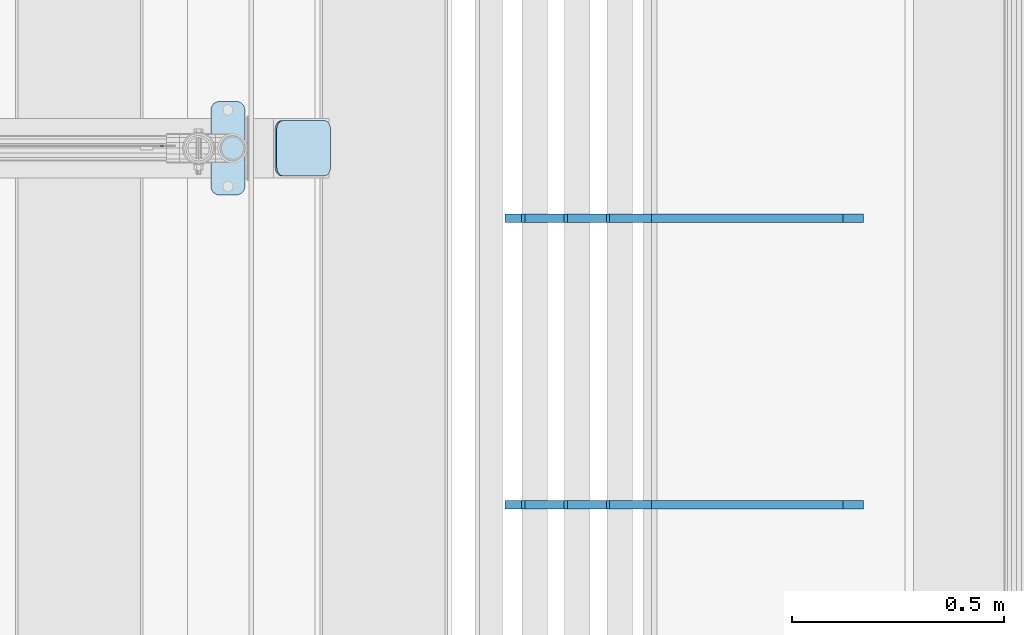
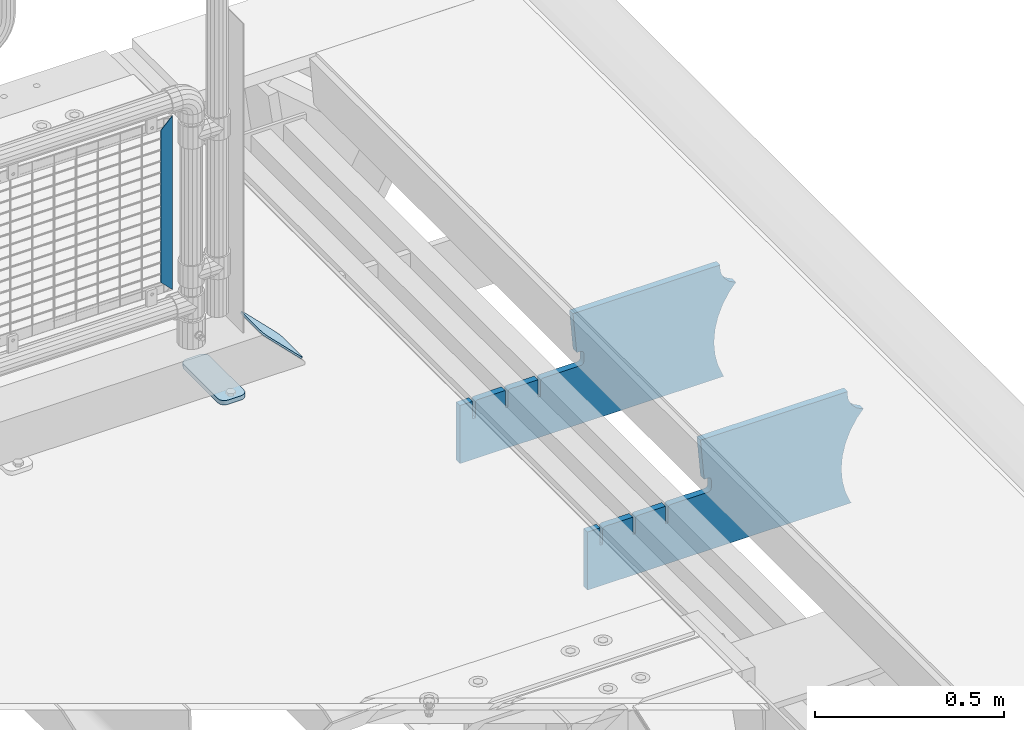
# One storey, part 178 of 193: 5 plates.
"""IFC2X3 building model written with IfcOpenShell, lengths in millimetres."""

from ifc_helpers import new_model, si_unit, frame, origin_with_axes, place, context, subcontext, project, spatial, faceted_brep, material, type_object, element, save


model = new_model("IFC2X3")

# Units and contexts
model_context = context("Model", 3, precision=1e-05, world=origin_with_axes())
body_context = subcontext(model_context, "Body", "Model", "MODEL_VIEW")
ifc_project = project(units=[si_unit("LENGTHUNIT", "METRE", prefix="MILLI"), si_unit("AREAUNIT", "SQUARE_METRE"), si_unit("VOLUMEUNIT", "CUBIC_METRE"), si_unit("MASSUNIT", "GRAM", prefix="KILO"), si_unit("TIMEUNIT", "SECOND"), si_unit("PLANEANGLEUNIT", "RADIAN"), si_unit("SOLIDANGLEUNIT", "STERADIAN"), si_unit("THERMODYNAMICTEMPERATUREUNIT", "DEGREE_CELSIUS"), si_unit("LUMINOUSINTENSITYUNIT", "LUMEN")], contexts=[model_context])

# Site, building, storey
site_placement = place(None, origin_with_axes())
site = spatial("IfcSite", under=ifc_project, at=site_placement, CompositionType="ELEMENT")
building_placement = place(site_placement, origin_with_axes())
building = spatial("IfcBuilding", under=site, at=building_placement, Name="Standard", CompositionType="ELEMENT")
storey_placement = place(building_placement, origin_with_axes())
storey = spatial("IfcBuildingStorey", under=building, at=storey_placement, Name="Undefined", CompositionType="ELEMENT", Elevation=0.0)

# Plates
ifc_material_1 = material(Name="Misc_Undefined")
plate_type_1 = type_object("IfcPlateType", PredefinedType="NOTDEFINED")
plate_1_placement = place(storey_placement, frame((-29073.5000000138, 28670.4997788013, 914.461469028508), z_axis=(0.706514791587334, 1.30000007553929e-08, -0.707698275586641), x_axis=(-0.707698275586628, 0.0, -0.706514791587347)))
element("IfcPlate", 1, at=plate_1_placement, inside=storey, type_object=plate_type_1, material=ifc_material_1, context=body_context, shape_type="Brep", body=[
    faceted_brep([(0.0, -1.49999999999636, 3.63797880709171e-12), (397.726470947258, -1.50000000000364, 398.392700195313), (397.726470947258, 1.49999999999636, 398.392700195316), (0.0, 1.50000000000364, 7.27595761418343e-12), (397.767883300774, -1.5, 348.895263671875), (397.767883300774, 1.5, 348.895263671879), (49.4561042785608, -1.5, -4.72937244921923e-11), (49.4561042785645, 1.5, -4.72937244921923e-11)], [[[0, 1, 2, 3]], [[1, 4, 5, 2]], [[4, 6, 7, 5]], [[6, 0, 3, 7]], [[5, 7, 3, 2]], [[6, 4, 1, 0]]]),
])
ifc_material_2 = material(Name="STEEL/S355J2")
plate_type_2 = type_object("IfcPlateType", PredefinedType="NOTDEFINED")
plate_2_placement = place(storey_placement, frame((-28990.0, 28774.5, 21.0199999999977), z_axis=(1.0, 0.0, 0.0), x_axis=(0.0, -1.0, 0.0)))
element("IfcPlate", 2, at=plate_2_placement, inside=storey, type_object=plate_type_2, material=ifc_material_2, context=body_context, shape_type="Brep", body=[
    faceted_brep([(0.0, -7.0, 20.0), (0.0, -7.0, 60.0), (0.0, 7.0, 60.0), (0.0, 7.0, 20.0), (0.384294391937146, -7.0, 63.9018064403208), (0.384294391937146, 7.0, 63.9018064403208), (1.52240934977453, -7.0, 67.6536686473009), (1.52240934977453, 7.0, 67.6536686473009), (3.37060775395003, -7.0, 71.1114046603907), (3.37060775395003, 7.0, 71.1114046603907), (5.8578643762703, -7.0, 74.1421356237297), (5.8578643762703, 7.0, 74.1421356237297), (8.88859533960931, -7.0, 76.62939224605), (8.88859533960931, 7.0, 76.62939224605), (12.3463313526991, -7.0, 78.4775906502255), (12.3463313526991, 7.0, 78.4775906502255), (16.0981935596792, -7.0, 79.6157056080629), (16.0981935596792, 7.0, 79.6157056080629), (20.0, -7.0, 80.0), (20.0, 7.0, 80.0), (200.0, -7.0, 80.0), (200.0, 7.0, 80.0), (203.901806440321, -7.0, 79.6157056080629), (203.901806440321, 7.0, 79.6157056080629), (207.653668647301, -7.0, 78.4775906502255), (207.653668647301, 7.0, 78.4775906502255), (211.111404660391, -7.0, 76.62939224605), (211.111404660391, 7.0, 76.62939224605), (214.14213562373, -7.0, 74.1421356237297), (214.14213562373, 7.0, 74.1421356237297), (216.62939224605, -7.0, 71.1114046603907), (216.62939224605, 7.0, 71.1114046603907), (218.477590650225, -7.0, 67.6536686473009), (218.477590650225, 7.0, 67.6536686473009), (219.615705608063, -7.0, 63.9018064403208), (219.615705608063, 7.0, 63.9018064403208), (220.0, -7.0, 60.0), (220.0, 7.0, 60.0), (220.0, -7.0, 20.0), (220.0, 7.0, 20.0), (219.615705608063, -7.0, 16.0981935596792), (219.615705608063, 7.0, 16.0981935596792), (218.477590650225, -7.0, 12.3463313526991), (218.477590650225, 7.0, 12.3463313526991), (216.62939224605, -7.0, 8.88859533960931), (216.62939224605, 7.0, 8.88859533960931), (214.14213562373, -7.0, 5.8578643762703), (214.14213562373, 7.0, 5.8578643762703), (211.111404660391, -7.0, 3.37060775395003), (211.111404660391, 7.0, 3.37060775395003), (207.653668647301, -7.0, 1.52240934977453), (207.653668647301, 7.0, 1.52240934977453), (203.901806440321, -7.0, 0.384294391937146), (203.901806440321, 7.0, 0.384294391937146), (200.0, -7.0, 0.0), (200.0, 7.0, 0.0), (20.0, -7.0, 0.0), (20.0, 7.0, 0.0), (16.0981935596792, -7.0, 0.384294391937146), (16.0981935596792, 7.0, 0.384294391937146), (12.3463313526991, -7.0, 1.52240934977453), (12.3463313526991, 7.0, 1.52240934977453), (8.88859533960931, -7.0, 3.37060775395003), (8.88859533960931, 7.0, 3.37060775395003), (5.8578643762703, -7.0, 5.8578643762703), (5.8578643762703, 7.0, 5.8578643762703), (3.37060775395003, -7.0, 8.88859533960931), (3.37060775395003, 7.0, 8.88859533960931), (1.52240934977453, -7.0, 12.3463313526991), (1.52240934977453, 7.0, 12.3463313526991), (0.384294391937146, -7.0, 16.0981935596792), (0.384294391937146, 7.0, 16.0981935596792)], [[[0, 1, 2, 3]], [[1, 4, 5, 2]], [[4, 6, 7, 5]], [[6, 8, 9, 7]], [[8, 10, 11, 9]], [[10, 12, 13, 11]], [[12, 14, 15, 13]], [[14, 16, 17, 15]], [[16, 18, 19, 17]], [[18, 20, 21, 19]], [[20, 22, 23, 21]], [[22, 24, 25, 23]], [[24, 26, 27, 25]], [[26, 28, 29, 27]], [[28, 30, 31, 29]], [[30, 32, 33, 31]], [[32, 34, 35, 33]], [[34, 36, 37, 35]], [[36, 38, 39, 37]], [[38, 40, 41, 39]], [[40, 42, 43, 41]], [[42, 44, 45, 43]], [[44, 46, 47, 45]], [[46, 48, 49, 47]], [[48, 50, 51, 49]], [[50, 52, 53, 51]], [[52, 54, 55, 53]], [[54, 56, 57, 55]], [[56, 58, 59, 57]], [[58, 60, 61, 59]], [[60, 62, 63, 61]], [[62, 64, 65, 63]], [[64, 66, 67, 65]], [[66, 68, 69, 67]], [[68, 70, 71, 69]], [[70, 0, 3, 71]], [[5, 7, 9, 11, 13, 15, 17, 19, 21, 23, 25, 27, 29, 31, 33, 35, 37, 39, 41, 43, 45, 47, 49, 51, 53, 55, 57, 59, 61, 63, 65, 67, 69, 71, 3, 2]], [[70, 68, 66, 64, 62, 60, 58, 56, 54, 52, 50, 48, 46, 44, 42, 40, 38, 36, 34, 32, 30, 28, 26, 24, 22, 20, 18, 16, 14, 12, 10, 8, 6, 4, 1, 0]]]),
])
plate_type_3 = type_object("IfcPlateType", PredefinedType="NOTDEFINED")
plate_3_placement = place(storey_placement, frame((-28836.8075815211, 28729.5, 166.254400376666), z_axis=(0.707410512925777, 0.0, -0.706802918925841), x_axis=(0.0, -1.0, 0.0)))
element("IfcPlate", 3, at=plate_3_placement, inside=storey, type_object=plate_type_3, material=ifc_material_2, context=body_context, shape_type="Brep", body=[
    faceted_brep([(0.0, -2.49999999999636, 20.0), (0.0, -2.5, 158.926651000977), (0.0, 2.50000000000364, 158.926651000977), (0.0, 2.5, 20.0), (0.384294391937146, -2.49999999999636, 162.828457441297), (0.384294391937146, 2.50000000000364, 162.828457441297), (1.52240934977453, -2.49999999999636, 166.580319648278), (1.52240934977453, 2.50000000000364, 166.580319648278), (3.37060775395003, -2.49999999999636, 170.038055661367), (3.37060775395003, 2.5, 170.038055661367), (5.8578643762703, -2.49999999999636, 173.068786624706), (5.8578643762703, 2.5, 173.06878662471), (8.88859533960931, -2.5, 175.55604324703), (8.88859533960931, 2.50000000000364, 175.55604324703), (12.3463313526991, -2.49999999999636, 177.404241651202), (12.3463313526991, 2.5, 177.404241651202), (16.0981935596792, -2.49999999999636, 178.542356609043), (16.0981935596792, 2.50000000000364, 178.542356609039), (20.0, -2.49999999999636, 178.926651000973), (20.0, 2.50000000000364, 178.926651000977), (110.0, -2.49999999999636, 178.926651000973), (110.0, 2.50000000000364, 178.926651000977), (113.901806440321, -2.49999999999636, 178.542356609043), (113.901806440321, 2.50000000000364, 178.542356609039), (117.653668647301, -2.49999999999636, 177.404241651202), (117.653668647301, 2.5, 177.404241651202), (121.111404660391, -2.5, 175.55604324703), (121.111404660391, 2.50000000000364, 175.55604324703), (124.14213562373, -2.49999999999636, 173.068786624706), (124.14213562373, 2.5, 173.06878662471), (126.62939224605, -2.49999999999636, 170.038055661367), (126.62939224605, 2.5, 170.038055661367), (128.477590650225, -2.49999999999636, 166.580319648278), (128.477590650225, 2.50000000000364, 166.580319648278), (129.615705608063, -2.49999999999636, 162.828457441297), (129.615705608063, 2.50000000000364, 162.828457441297), (130.0, -2.5, 158.926651000977), (130.0, 2.50000000000364, 158.926651000977), (130.0, -2.49999999999636, 20.0), (130.0, 2.5, 20.0), (129.615705608063, -2.49999999999636, 16.0981935596792), (129.615705608063, 2.5, 16.0981935596792), (128.477590650225, -2.49999999999636, 12.3463313526991), (128.477590650225, 2.50000000000364, 12.3463313526991), (126.62939224605, -2.5, 8.88859533960931), (126.62939224605, 2.5, 8.88859533960931), (124.14213562373, -2.5, 5.8578643762703), (124.14213562373, 2.5, 5.8578643762703), (121.111404660391, -2.49999999999636, 3.37060775395003), (121.111404660391, 2.5, 3.37060775395003), (117.653668647301, -2.49999999999636, 1.52240934977453), (117.653668647301, 2.50000000000364, 1.52240934977453), (113.901806440321, -2.49999999999636, 0.384294391933508), (113.901806440321, 2.50000000000364, 0.384294391937146), (110.0, -2.49999999999636, 0.0), (110.0, 2.50000000000364, 0.0), (20.0, -2.49999999999636, 0.0), (20.0, 2.50000000000364, 0.0), (16.0981935596792, -2.49999999999636, 0.384294391933508), (16.0981935596792, 2.50000000000364, 0.384294391937146), (12.3463313526991, -2.49999999999636, 1.52240934977453), (12.3463313526991, 2.50000000000364, 1.52240934977453), (8.88859533960931, -2.49999999999636, 3.37060775395003), (8.88859533960931, 2.5, 3.37060775395003), (5.8578643762703, -2.5, 5.8578643762703), (5.8578643762703, 2.5, 5.8578643762703), (3.37060775395003, -2.5, 8.88859533960931), (3.37060775395003, 2.5, 8.88859533960931), (1.52240934977453, -2.49999999999636, 12.3463313526991), (1.52240934977453, 2.50000000000364, 12.3463313526991), (0.384294391937146, -2.49999999999636, 16.0981935596792), (0.384294391937146, 2.5, 16.0981935596792)], [[[0, 1, 2, 3]], [[1, 4, 5, 2]], [[4, 6, 7, 5]], [[6, 8, 9, 7]], [[8, 10, 11, 9]], [[10, 12, 13, 11]], [[12, 14, 15, 13]], [[14, 16, 17, 15]], [[16, 18, 19, 17]], [[18, 20, 21, 19]], [[20, 22, 23, 21]], [[22, 24, 25, 23]], [[24, 26, 27, 25]], [[26, 28, 29, 27]], [[28, 30, 31, 29]], [[30, 32, 33, 31]], [[32, 34, 35, 33]], [[34, 36, 37, 35]], [[36, 38, 39, 37]], [[38, 40, 41, 39]], [[40, 42, 43, 41]], [[42, 44, 45, 43]], [[44, 46, 47, 45]], [[46, 48, 49, 47]], [[48, 50, 51, 49]], [[50, 52, 53, 51]], [[52, 54, 55, 53]], [[54, 56, 57, 55]], [[56, 58, 59, 57]], [[58, 60, 61, 59]], [[60, 62, 63, 61]], [[62, 64, 65, 63]], [[64, 66, 67, 65]], [[66, 68, 69, 67]], [[68, 70, 71, 69]], [[70, 0, 3, 71]], [[5, 7, 9, 11, 13, 15, 17, 19, 21, 23, 25, 27, 29, 31, 33, 35, 37, 39, 41, 43, 45, 47, 49, 51, 53, 55, 57, 59, 61, 63, 65, 67, 69, 71, 3, 2]], [[70, 68, 66, 64, 62, 60, 58, 56, 54, 52, 50, 48, 46, 44, 42, 40, 38, 36, 34, 32, 30, 28, 26, 24, 22, 20, 18, 16, 14, 12, 10, 8, 6, 4, 1, 0]]]),
])
ifc_material_3 = material(Name="STEEL/S355N")
plate_type_4 = type_object("IfcPlateType", PredefinedType="NOTDEFINED")
plate_4_placement = place(storey_placement, frame((-27457.0817660324, 27824.9992828369, -374.002067436516), z_axis=(0.0, 0.0, 1.0), x_axis=(-1.0, 0.0, 0.0)))
element("IfcPlate", 4, at=plate_4_placement, inside=storey, type_object=plate_type_4, material=ifc_material_3, context=body_context, shape_type="Brep", body=[
    faceted_brep([(801.919404066546, -10.0, 188.0), (801.919404066546, 10.0, 188.0), (801.919404066546, 10.0, 132.002067436952), (801.919404066546, -10.0, 132.002067436952), (793.919404066546, 10.0, 132.002067436952), (793.919404066546, -10.0, 132.002067436952), (793.919404066546, 10.0, 180.002067436952), (793.919404066546, -10.0, 180.002067436952), (793.527856196906, 10.0, 182.474203391951), (793.527856196906, -10.0, 182.474203391951), (792.391540021545, 10.0, 184.704349455291), (792.391540021545, -10.0, 184.704349455291), (790.621686084887, 10.0, 186.474203391951), (790.621686084887, -10.0, 186.474203391951), (788.391540021545, 10.0, 187.610519567313), (788.391540021545, -10.0, 187.610519567313), (785.919404066546, -10.0, 188.002067436952), (785.919404066546, 10.0, 188.0), (841.0, -10.0, 188.0), (841.0, -10.0, 0.0), (841.0, 10.0, 0.0), (841.0, 10.0, 188.0), (33.3619566736015, -10.0, 0.0), (33.3619566736015, 10.0, 0.0), (36.2350612208174, -10.0, 4.68848050267007), (36.2350612208174, 10.0, 4.68848050267007), (51.4877592159428, -10.0, 41.5117508652783), (51.4877592159428, 10.0, 41.5117508652783), (60.792242588137, -10.0, 80.2677133162963), (60.792242588137, 10.0, 80.2677133162963), (63.9194040769726, -10.0, 120.002067436515), (63.9194040769726, 10.0, 120.002067436515), (60.792242588137, -10.0, 159.736421556734), (60.792242588137, 10.0, 159.736421556734), (51.4877592159428, -10.0, 198.492384007752), (51.4877592159428, 10.0, 198.492384007752), (36.2350612208174, -10.0, 235.31565437036), (36.2350612208174, 10.0, 235.31565437036), (15.4097206482074, -10.0, 269.299521518803), (15.4097206482074, 10.0, 269.299521518803), (-3.35474438098754, -10.0, 291.269887256574), (-3.35474438098754, 10.0, 291.269887256574), (-2.36881039375294, -10.0, 291.426043859339), (-2.36881039375294, 10.0, 291.426043859339), (17.1449676604716, -10.0, 301.368810393754), (17.1449676604716, 10.0, 301.368810393754), (32.6311896062471, -10.0, 316.855032339527), (32.6311896062471, 10.0, 316.855032339527), (42.573956140659, -10.0, 336.368810393754), (42.573956140659, 10.0, 336.368810393754), (46.0, -10.0, 358.0), (46.0, 10.0, 358.0), (45.0495205499137, -10.0, 364.001091067617), (45.0495205499137, 10.0, 364.001091067617), (495.040008544922, -10.0, 364.010009765625), (495.040008544922, 10.0, 364.010009765625), (483.600036621094, -10.0, 233.759994506836), (483.600036621094, 10.0, 233.759994506836), (472.0, -10.0, 233.759994506836), (472.0, 10.0, 233.759994506836), (468.909830056251, -10.0, 233.270559669787), (468.909830056251, 10.0, 233.270559669787), (466.122147477075, -10.0, 231.850164450585), (466.122147477075, 10.0, 231.850164450585), (463.909830056251, -10.0, 229.637847029761), (463.909830056251, 10.0, 229.637847029761), (462.489434837047, -10.0, 226.850164450585), (462.489434837047, 10.0, 226.850164450585), (462.0, -10.0, 223.759994506836), (462.0, 10.0, 223.759994506836), (462.0, -10.0, 198.0), (462.0, 10.0, 198.0), (462.489434837047, -10.0, 194.909830056251), (462.489434837047, 10.0, 194.909830056251), (463.909830056251, -10.0, 192.122147477075), (463.909830056251, 10.0, 192.122147477075), (466.122147477075, -10.0, 189.909830056251), (466.122147477075, 10.0, 189.909830056251), (468.909830056251, -10.0, 188.489434837048), (468.909830056251, 10.0, 188.489434837048), (472.0, -10.0, 188.0), (472.0, 10.0, 188.0), (585.919404066546, -10.0, 188.002067436952), (585.919404066546, 10.0, 188.0), (588.391540021545, -10.0, 187.610519567313), (588.391540021545, 10.0, 187.610519567313), (590.621686084887, -10.0, 186.474203391951), (590.621686084887, 10.0, 186.474203391951), (592.391540021545, -10.0, 184.704349455291), (592.391540021545, 10.0, 184.704349455291), (593.527856196906, -10.0, 182.474203391951), (593.527856196906, 10.0, 182.474203391951), (593.919404066546, -10.0, 180.002067436952), (593.919404066546, 10.0, 180.002067436952), (593.919404066546, -10.0, 132.002067436952), (593.919404066546, 10.0, 132.002067436952), (601.919404066546, -10.0, 132.002067436952), (601.919404066546, 10.0, 132.002067436952), (601.919404066546, -10.0, 188.0), (601.919404066546, 10.0, 188.0), (685.919404066546, -10.0, 188.002067436952), (685.919404066546, 10.0, 188.0), (688.391540021545, -10.0, 187.610519567313), (688.391540021545, 10.0, 187.610519567313), (690.621686084887, -10.0, 186.474203391951), (690.621686084887, 10.0, 186.474203391951), (692.391540021545, -10.0, 184.704349455291), (692.391540021545, 10.0, 184.704349455291), (693.527856196906, -10.0, 182.474203391951), (693.527856196906, 10.0, 182.474203391951), (693.919404066546, -10.0, 180.002067436952), (693.919404066546, 10.0, 180.002067436952), (693.919404066546, -10.0, 132.002067436952), (693.919404066546, 10.0, 132.002067436952), (701.919404066546, -10.0, 132.002067436952), (701.919404066546, 10.0, 132.002067436952), (701.919404066546, -10.0, 188.0), (701.919404066546, 10.0, 188.0)], [[[0, 1, 2, 3]], [[3, 2, 4, 5]], [[5, 4, 6, 7]], [[7, 6, 8, 9]], [[9, 8, 10, 11]], [[11, 10, 12, 13]], [[13, 12, 14, 15]], [[16, 15, 14, 17]], [[18, 19, 20, 21]], [[20, 19, 22, 23]], [[22, 24, 25, 23]], [[26, 27, 25, 24]], [[28, 29, 27, 26]], [[30, 31, 29, 28]], [[32, 33, 31, 30]], [[34, 35, 33, 32]], [[36, 37, 35, 34]], [[38, 39, 37, 36]], [[39, 38, 40, 41]], [[40, 42, 43, 41]], [[44, 45, 43, 42]], [[46, 47, 45, 44]], [[48, 49, 47, 46]], [[50, 51, 49, 48]], [[52, 53, 51, 50]], [[54, 55, 53, 52]], [[54, 56, 57, 55]], [[56, 58, 59, 57]], [[58, 60, 61, 59]], [[60, 62, 63, 61]], [[62, 64, 65, 63]], [[64, 66, 67, 65]], [[66, 68, 69, 67]], [[68, 70, 71, 69]], [[70, 72, 73, 71]], [[72, 74, 75, 73]], [[74, 76, 77, 75]], [[76, 78, 79, 77]], [[78, 80, 81, 79]], [[81, 80, 82, 83]], [[82, 84, 85, 83]], [[86, 87, 85, 84]], [[88, 89, 87, 86]], [[90, 91, 89, 88]], [[92, 93, 91, 90]], [[94, 95, 93, 92]], [[96, 97, 95, 94]], [[98, 99, 97, 96]], [[99, 98, 100, 101]], [[100, 102, 103, 101]], [[104, 105, 103, 102]], [[106, 107, 105, 104]], [[108, 109, 107, 106]], [[110, 111, 109, 108]], [[112, 113, 111, 110]], [[114, 115, 113, 112]], [[116, 117, 115, 114]], [[117, 116, 16, 17]], [[12, 10, 8, 6, 4, 2, 1, 21, 20, 23, 25, 27, 29, 31, 33, 35, 37, 39, 41, 43, 45, 47, 49, 51, 53, 55, 57, 59, 61, 63, 65, 67, 69, 71, 73, 75, 77, 79, 81, 83, 85, 87, 89, 91, 93, 95, 97, 99, 101, 103, 105, 107, 109, 111, 113, 115, 117, 17, 14]], [[18, 21, 1, 0]], [[116, 114, 112, 110, 108, 106, 104, 102, 100, 98, 96, 94, 92, 90, 88, 86, 84, 82, 80, 78, 76, 74, 72, 70, 68, 66, 64, 62, 60, 58, 56, 54, 52, 50, 48, 46, 44, 42, 40, 38, 36, 34, 32, 30, 28, 26, 24, 22, 19, 18, 0, 3, 5, 7, 9, 11, 13, 15, 16]]]),
])
plate_5_placement = place(storey_placement, frame((-27457.0817660324, 28499.9992828369, -374.002067436516), z_axis=(0.0, 0.0, 1.0), x_axis=(-1.0, 0.0, 0.0)))
element("IfcPlate", 5, at=plate_5_placement, inside=storey, type_object=plate_type_4, material=ifc_material_3, context=body_context, shape_type="Brep", body=[
    faceted_brep([(801.919404066546, -10.0, 188.0), (801.919404066546, 10.0, 188.0), (801.919404066546, 10.0, 132.002067436952), (801.919404066546, -10.0, 132.002067436952), (793.919404066546, 10.0, 132.002067436952), (793.919404066546, -10.0, 132.002067436952), (793.919404066546, 10.0, 180.002067436952), (793.919404066546, -10.0, 180.002067436952), (793.527856196906, 10.0, 182.474203391951), (793.527856196906, -10.0, 182.474203391951), (792.391540021545, 10.0, 184.704349455291), (792.391540021545, -10.0, 184.704349455291), (790.621686084887, 10.0, 186.474203391951), (790.621686084887, -10.0, 186.474203391951), (788.391540021545, 10.0, 187.610519567313), (788.391540021545, -10.0, 187.610519567313), (785.919404066546, -10.0, 188.002067436952), (785.919404066546, 10.0, 188.0), (841.0, -10.0, 188.0), (841.0, -10.0, 0.0), (841.0, 10.0, 0.0), (841.0, 10.0, 188.0), (33.3619566736015, -10.0, 0.0), (33.3619566736015, 10.0, 0.0), (36.2350612208174, -10.0, 4.68848050267007), (36.2350612208174, 10.0, 4.68848050267007), (51.4877592159428, -10.0, 41.5117508652783), (51.4877592159428, 10.0, 41.5117508652783), (60.792242588137, -10.0, 80.2677133162963), (60.792242588137, 10.0, 80.2677133162963), (63.9194040769726, -10.0, 120.002067436515), (63.9194040769726, 10.0, 120.002067436515), (60.792242588137, -10.0, 159.736421556734), (60.792242588137, 10.0, 159.736421556734), (51.4877592159428, -10.0, 198.492384007752), (51.4877592159428, 10.0, 198.492384007752), (36.2350612208174, -10.0, 235.31565437036), (36.2350612208174, 10.0, 235.31565437036), (15.4097206482074, -10.0, 269.299521518803), (15.4097206482074, 10.0, 269.299521518803), (-3.35474438098754, -10.0, 291.269887256574), (-3.35474438098754, 10.0, 291.269887256574), (-2.36881039375294, -10.0, 291.426043859339), (-2.36881039375294, 10.0, 291.426043859339), (17.1449676604716, -10.0, 301.368810393754), (17.1449676604716, 10.0, 301.368810393754), (32.6311896062471, -10.0, 316.855032339527), (32.6311896062471, 10.0, 316.855032339527), (42.573956140659, -10.0, 336.368810393754), (42.573956140659, 10.0, 336.368810393754), (46.0, -10.0, 358.0), (46.0, 10.0, 358.0), (45.0495205499137, -10.0, 364.001091067617), (45.0495205499137, 10.0, 364.001091067617), (495.040008544922, -10.0, 364.010009765625), (495.040008544922, 10.0, 364.010009765625), (483.600036621094, -10.0, 233.759994506836), (483.600036621094, 10.0, 233.759994506836), (472.0, -10.0, 233.759994506836), (472.0, 10.0, 233.759994506836), (468.909830056251, -10.0, 233.270559669787), (468.909830056251, 10.0, 233.270559669787), (466.122147477075, -10.0, 231.850164450585), (466.122147477075, 10.0, 231.850164450585), (463.909830056251, -10.0, 229.637847029761), (463.909830056251, 10.0, 229.637847029761), (462.489434837047, -10.0, 226.850164450585), (462.489434837047, 10.0, 226.850164450585), (462.0, -10.0, 223.759994506836), (462.0, 10.0, 223.759994506836), (462.0, -10.0, 198.0), (462.0, 10.0, 198.0), (462.489434837047, -10.0, 194.909830056251), (462.489434837047, 10.0, 194.909830056251), (463.909830056251, -10.0, 192.122147477075), (463.909830056251, 10.0, 192.122147477075), (466.122147477075, -10.0, 189.909830056251), (466.122147477075, 10.0, 189.909830056251), (468.909830056251, -10.0, 188.489434837048), (468.909830056251, 10.0, 188.489434837048), (472.0, -10.0, 188.0), (472.0, 10.0, 188.0), (585.919404066546, -10.0, 188.002067436952), (585.919404066546, 10.0, 188.0), (588.391540021545, -10.0, 187.610519567313), (588.391540021545, 10.0, 187.610519567313), (590.621686084887, -10.0, 186.474203391951), (590.621686084887, 10.0, 186.474203391951), (592.391540021545, -10.0, 184.704349455291), (592.391540021545, 10.0, 184.704349455291), (593.527856196906, -10.0, 182.474203391951), (593.527856196906, 10.0, 182.474203391951), (593.919404066546, -10.0, 180.002067436952), (593.919404066546, 10.0, 180.002067436952), (593.919404066546, -10.0, 132.002067436952), (593.919404066546, 10.0, 132.002067436952), (601.919404066546, -10.0, 132.002067436952), (601.919404066546, 10.0, 132.002067436952), (601.919404066546, -10.0, 188.0), (601.919404066546, 10.0, 188.0), (685.919404066546, -10.0, 188.002067436952), (685.919404066546, 10.0, 188.0), (688.391540021545, -10.0, 187.610519567313), (688.391540021545, 10.0, 187.610519567313), (690.621686084887, -10.0, 186.474203391951), (690.621686084887, 10.0, 186.474203391951), (692.391540021545, -10.0, 184.704349455291), (692.391540021545, 10.0, 184.704349455291), (693.527856196906, -10.0, 182.474203391951), (693.527856196906, 10.0, 182.474203391951), (693.919404066546, -10.0, 180.002067436952), (693.919404066546, 10.0, 180.002067436952), (693.919404066546, -10.0, 132.002067436952), (693.919404066546, 10.0, 132.002067436952), (701.919404066546, -10.0, 132.002067436952), (701.919404066546, 10.0, 132.002067436952), (701.919404066546, -10.0, 188.0), (701.919404066546, 10.0, 188.0)], [[[0, 1, 2, 3]], [[3, 2, 4, 5]], [[5, 4, 6, 7]], [[7, 6, 8, 9]], [[9, 8, 10, 11]], [[11, 10, 12, 13]], [[13, 12, 14, 15]], [[16, 15, 14, 17]], [[18, 19, 20, 21]], [[20, 19, 22, 23]], [[22, 24, 25, 23]], [[26, 27, 25, 24]], [[28, 29, 27, 26]], [[30, 31, 29, 28]], [[32, 33, 31, 30]], [[34, 35, 33, 32]], [[36, 37, 35, 34]], [[38, 39, 37, 36]], [[39, 38, 40, 41]], [[40, 42, 43, 41]], [[44, 45, 43, 42]], [[46, 47, 45, 44]], [[48, 49, 47, 46]], [[50, 51, 49, 48]], [[52, 53, 51, 50]], [[54, 55, 53, 52]], [[54, 56, 57, 55]], [[56, 58, 59, 57]], [[58, 60, 61, 59]], [[60, 62, 63, 61]], [[62, 64, 65, 63]], [[64, 66, 67, 65]], [[66, 68, 69, 67]], [[68, 70, 71, 69]], [[70, 72, 73, 71]], [[72, 74, 75, 73]], [[74, 76, 77, 75]], [[76, 78, 79, 77]], [[78, 80, 81, 79]], [[81, 80, 82, 83]], [[82, 84, 85, 83]], [[86, 87, 85, 84]], [[88, 89, 87, 86]], [[90, 91, 89, 88]], [[92, 93, 91, 90]], [[94, 95, 93, 92]], [[96, 97, 95, 94]], [[98, 99, 97, 96]], [[99, 98, 100, 101]], [[100, 102, 103, 101]], [[104, 105, 103, 102]], [[106, 107, 105, 104]], [[108, 109, 107, 106]], [[110, 111, 109, 108]], [[112, 113, 111, 110]], [[114, 115, 113, 112]], [[116, 117, 115, 114]], [[117, 116, 16, 17]], [[12, 10, 8, 6, 4, 2, 1, 21, 20, 23, 25, 27, 29, 31, 33, 35, 37, 39, 41, 43, 45, 47, 49, 51, 53, 55, 57, 59, 61, 63, 65, 67, 69, 71, 73, 75, 77, 79, 81, 83, 85, 87, 89, 91, 93, 95, 97, 99, 101, 103, 105, 107, 109, 111, 113, 115, 117, 17, 14]], [[18, 21, 1, 0]], [[116, 114, 112, 110, 108, 106, 104, 102, 100, 98, 96, 94, 92, 90, 88, 86, 84, 82, 80, 78, 76, 74, 72, 70, 68, 66, 64, 62, 60, 58, 56, 54, 52, 50, 48, 46, 44, 42, 40, 38, 36, 34, 32, 30, 28, 26, 24, 22, 19, 18, 0, 3, 5, 7, 9, 11, 13, 15, 16]]]),
])

save(model, "model.ifc")
